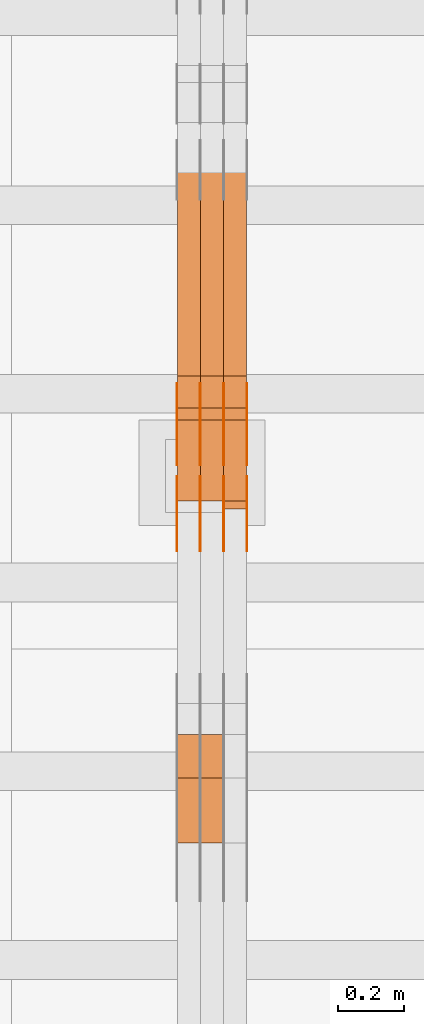
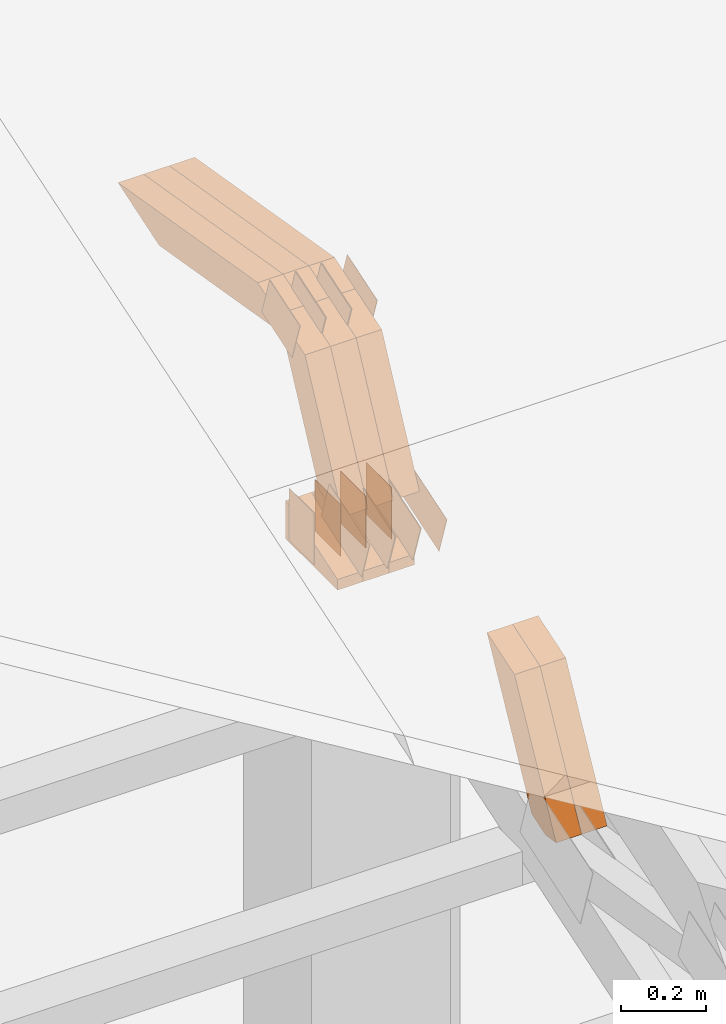
# One storey, part 145 of 385: 29 proxies.
"""IFC2X3 building model written with IfcOpenShell, lengths in millimetres."""

from ifc_helpers import new_model, entity, si_unit, converted_unit, derived_unit, direction, frame, frame_2d, origin, place, context, subcontext, project, spatial, polyline, rectangle, outline, extrude, source, transform, mapped, material, type_object, type_shapes, element, save


model = new_model("IFC2X3")

# Units and contexts
model_context = context("Model", 3, precision=0.01, world=origin(), true_north=direction((6.12303176911189e-17, 1.0)))
body_context = subcontext(model_context, "Body", "Model", "MODEL_VIEW")
ifc_project = project(units=[si_unit("LENGTHUNIT", "METRE", prefix="MILLI"), si_unit("AREAUNIT", "SQUARE_METRE"), si_unit("VOLUMEUNIT", "CUBIC_METRE"), converted_unit("PLANEANGLEUNIT", "DEGREE", entity("IfcRatioMeasure", 0.0174532925199433), si_unit("PLANEANGLEUNIT", "RADIAN"), dimensions=[0, 0, 0, 0, 0, 0, 0]), si_unit("MASSUNIT", "GRAM", prefix="KILO"), derived_unit("MASSDENSITYUNIT", [(si_unit("MASSUNIT", "GRAM", prefix="KILO"), 1), (si_unit("LENGTHUNIT", "METRE"), -3)]), si_unit("TIMEUNIT", "SECOND"), si_unit("FREQUENCYUNIT", "HERTZ"), si_unit("THERMODYNAMICTEMPERATUREUNIT", "DEGREE_CELSIUS"), derived_unit("THERMALTRANSMITTANCEUNIT", [(si_unit("MASSUNIT", "GRAM", prefix="KILO"), 1), (si_unit("THERMODYNAMICTEMPERATUREUNIT", "KELVIN"), -1), (si_unit("TIMEUNIT", "SECOND"), -3)]), derived_unit("VOLUMETRICFLOWRATEUNIT", [(si_unit("LENGTHUNIT", "METRE"), 3), (si_unit("TIMEUNIT", "SECOND"), -1)]), si_unit("ELECTRICCURRENTUNIT", "AMPERE"), si_unit("ELECTRICVOLTAGEUNIT", "VOLT"), si_unit("POWERUNIT", "WATT"), si_unit("FORCEUNIT", "NEWTON", prefix="KILO"), si_unit("ILLUMINANCEUNIT", "LUX"), si_unit("LUMINOUSFLUXUNIT", "LUMEN"), si_unit("LUMINOUSINTENSITYUNIT", "CANDELA"), derived_unit("USERDEFINED", [(si_unit("MASSUNIT", "GRAM", prefix="KILO"), -1), (si_unit("LENGTHUNIT", "METRE"), -2), (si_unit("TIMEUNIT", "SECOND"), 3), (si_unit("LUMINOUSFLUXUNIT", "LUMEN"), 1)]), derived_unit("LINEARVELOCITYUNIT", [(si_unit("LENGTHUNIT", "METRE"), 1), (si_unit("TIMEUNIT", "SECOND"), -1)]), si_unit("PRESSUREUNIT", "PASCAL"), derived_unit("USERDEFINED", [(si_unit("LENGTHUNIT", "METRE"), -2), (si_unit("MASSUNIT", "GRAM", prefix="KILO"), 1), (si_unit("TIMEUNIT", "SECOND"), -2)])], contexts=[model_context])

# Site, building, storey
site_placement = place(None, origin())
site = spatial("IfcSite", under=ifc_project, at=site_placement, CompositionType="ELEMENT")
building_placement = place(site_placement, origin())
building = spatial("IfcBuilding", under=site, at=building_placement, CompositionType="ELEMENT")
storey_placement = place(building_placement, origin())
storey = spatial("IfcBuildingStorey", under=building, at=storey_placement, Name="Default", CompositionType="ELEMENT", Elevation=0.0)

# Proxies
ifc_material_1 = material(Name="IfcSurfaceStyle #275952")
building_element_proxy_type_1 = type_object("IfcBuildingElementProxyType", PredefinedType="NOTDEFINED", material=ifc_material_1)
shared_shape_1 = source(origin(), body_context, "Body", "SweptSolid", [
    extrude(outline(polyline([(-99.9997874178038, -60.0000528641967), (99.9998102700997, -60.0000528641967), (99.9998251396068, 60.0000528641967), (-99.9998479919027, 60.0000528641967), (-99.9997874178038, -60.0000528641967)])), frame((99.9999918898597, 60.0000528641967, 0.0), z_axis=(0.0, 0.0, 1.0), x_axis=(-1.0, 0.0, 0.0)), (0.0, 0.0, 1.0), 1.3),
])
type_shapes(building_element_proxy_type_1, [shared_shape_1])
proxy_1_placement = place(building_placement, frame((21386.3, 11991.9568177725, 3072.52282247925), z_axis=(-1.0, 0.0, 0.0), x_axis=(0.0, 0.951056516295124, 0.309016994375039)))
element("IfcBuildingElementProxy", 1, at=proxy_1_placement, inside=storey, type_object=building_element_proxy_type_1, material=ifc_material_1, context=body_context, shape_type="MappedRepresentation", body=[
    mapped(shared_shape_1, transform((0.0, 0.0, 0.0), scale=1.0)),
])
ifc_material_2 = material(Name="IfcSurfaceStyle #275895")
building_element_proxy_type_2 = type_object("IfcBuildingElementProxyType", PredefinedType="NOTDEFINED", material=ifc_material_2)
shared_shape_2 = source(origin(), body_context, "Body", "SweptSolid", [
    extrude(outline(polyline([(-99.9997874178038, -60.0000528641967), (99.9998102700997, -60.0000528641967), (99.9998251396068, 60.0000528641967), (-99.9998479919027, 60.0000528641967), (-99.9997874178038, -60.0000528641967)])), frame((99.9999918898597, 60.0000528641967, 0.0), z_axis=(0.0, 0.0, 1.0), x_axis=(-1.0, 0.0, 0.0)), (0.0, 0.0, 1.0), 1.3),
])
type_shapes(building_element_proxy_type_2, [shared_shape_2])
proxy_2_placement = place(building_placement, frame((21315.0, 11991.9568177725, 3072.52282247925), z_axis=(-1.0, 0.0, 0.0), x_axis=(0.0, 0.951056516295124, 0.309016994375039)))
element("IfcBuildingElementProxy", 2, at=proxy_2_placement, inside=storey, type_object=building_element_proxy_type_2, material=ifc_material_2, context=body_context, shape_type="MappedRepresentation", body=[
    mapped(shared_shape_2, transform((0.0, 0.0, 0.0), scale=1.0)),
])
ifc_material_3 = material(Name="IfcSurfaceStyle #275838")
building_element_proxy_type_3 = type_object("IfcBuildingElementProxyType", PredefinedType="NOTDEFINED", material=ifc_material_3)
shared_shape_3 = source(origin(), body_context, "Body", "SweptSolid", [
    extrude(outline(polyline([(-99.9997874178038, -60.0000528641967), (99.9998102700997, -60.0000528641967), (99.9998251396068, 60.0000528641967), (-99.9998479919027, 60.0000528641967), (-99.9997874178038, -60.0000528641967)])), frame((99.9999918898597, 60.0000528641967, 0.0), z_axis=(0.0, 0.0, 1.0), x_axis=(-1.0, 0.0, 0.0)), (0.0, 0.0, 1.0), 1.3),
])
type_shapes(building_element_proxy_type_3, [shared_shape_3])
proxy_3_placement = place(building_placement, frame((21316.3, 11991.9568177725, 3072.52282247925), z_axis=(-1.0, 0.0, 0.0), x_axis=(0.0, 0.951056516295124, 0.309016994375039)))
element("IfcBuildingElementProxy", 3, at=proxy_3_placement, inside=storey, type_object=building_element_proxy_type_3, material=ifc_material_3, context=body_context, shape_type="MappedRepresentation", body=[
    mapped(shared_shape_3, transform((0.0, 0.0, 0.0), scale=1.0)),
])
ifc_material_4 = material(Name="IfcSurfaceStyle #275781")
building_element_proxy_type_4 = type_object("IfcBuildingElementProxyType", PredefinedType="NOTDEFINED", material=ifc_material_4)
shared_shape_4 = source(origin(), body_context, "Body", "SweptSolid", [
    extrude(outline(polyline([(-99.9997874178038, -60.0000528641967), (99.9998102700997, -60.0000528641967), (99.9998251396068, 60.0000528641967), (-99.9998479919027, 60.0000528641967), (-99.9997874178038, -60.0000528641967)])), frame((99.9999918898597, 60.0000528641967, 0.0), z_axis=(0.0, 0.0, 1.0), x_axis=(-1.0, 0.0, 0.0)), (0.0, 0.0, 1.0), 1.29999999999998),
])
type_shapes(building_element_proxy_type_4, [shared_shape_4])
proxy_4_placement = place(building_placement, frame((21245.0, 11991.9568177725, 3072.52282247925), z_axis=(-1.0, 0.0, 0.0), x_axis=(0.0, 0.951056516295124, 0.309016994375039)))
element("IfcBuildingElementProxy", 4, at=proxy_4_placement, inside=storey, type_object=building_element_proxy_type_4, material=ifc_material_4, context=body_context, shape_type="MappedRepresentation", body=[
    mapped(shared_shape_4, transform((0.0, 0.0, 0.0), scale=1.0)),
])
ifc_material_5 = material(Name="IfcSurfaceStyle #275724")
building_element_proxy_type_5 = type_object("IfcBuildingElementProxyType", PredefinedType="NOTDEFINED", material=ifc_material_5)
shared_shape_5 = source(origin(), body_context, "Body", "SweptSolid", [
    extrude(outline(polyline([(-99.9997874178038, -60.0000528641967), (99.9998102700997, -60.0000528641967), (99.9998251396068, 60.0000528641967), (-99.9998479919027, 60.0000528641967), (-99.9997874178038, -60.0000528641967)])), frame((99.9999918898597, 60.0000528641967, 0.0), z_axis=(0.0, 0.0, 1.0), x_axis=(-1.0, 0.0, 0.0)), (0.0, 0.0, 1.0), 1.29999999999998),
])
type_shapes(building_element_proxy_type_5, [shared_shape_5])
proxy_5_placement = place(building_placement, frame((21246.3, 11991.9568177725, 3072.52282247925), z_axis=(-1.0, 0.0, 0.0), x_axis=(0.0, 0.951056516295124, 0.309016994375039)))
element("IfcBuildingElementProxy", 5, at=proxy_5_placement, inside=storey, type_object=building_element_proxy_type_5, material=ifc_material_5, context=body_context, shape_type="MappedRepresentation", body=[
    mapped(shared_shape_5, transform((0.0, 0.0, 0.0), scale=1.0)),
])
ifc_material_6 = material(Name="IfcSurfaceStyle #275667")
building_element_proxy_type_6 = type_object("IfcBuildingElementProxyType", PredefinedType="NOTDEFINED", material=ifc_material_6)
shared_shape_6 = source(origin(), body_context, "Body", "SweptSolid", [
    extrude(outline(polyline([(-99.9997874178038, -60.0000528641967), (99.9998102700997, -60.0000528641967), (99.9998251396068, 60.0000528641967), (-99.9998479919027, 60.0000528641967), (-99.9997874178038, -60.0000528641967)])), frame((99.9999918898597, 60.0000528641967, 0.0), z_axis=(0.0, 0.0, 1.0), x_axis=(-1.0, 0.0, 0.0)), (0.0, 0.0, 1.0), 1.29999999999999),
])
type_shapes(building_element_proxy_type_6, [shared_shape_6])
proxy_6_placement = place(building_placement, frame((21175.0, 11991.9568177725, 3072.52282247925), z_axis=(-1.0, 0.0, 0.0), x_axis=(0.0, 0.951056516295124, 0.309016994375039)))
element("IfcBuildingElementProxy", 6, at=proxy_6_placement, inside=storey, type_object=building_element_proxy_type_6, material=ifc_material_6, context=body_context, shape_type="MappedRepresentation", body=[
    mapped(shared_shape_6, transform((0.0, 0.0, 0.0), scale=1.0)),
])
ifc_material_7 = material(Name="IfcSurfaceStyle #275610")
building_element_proxy_type_7 = type_object("IfcBuildingElementProxyType", PredefinedType="NOTDEFINED", material=ifc_material_7)
shared_shape_7 = source(origin(), body_context, "Body", "SweptSolid", [
    extrude(rectangle(XDim=150.0, YDim=119.999999999985, at=frame_2d((-7.105427357601e-15, 0.0), x_axis=(1.0, 0.0))), frame((75.0, 60.0, 0.0), z_axis=(0.0, 0.0, 1.0), x_axis=(-1.0, 0.0, 0.0)), (0.0, 0.0, 1.0), 1.3),
])
type_shapes(building_element_proxy_type_7, [shared_shape_7])
proxy_7_placement = place(building_placement, frame((21386.3, 12372.95703125, 3007.04687500001), z_axis=(-1.0, 0.0, 0.0), x_axis=(0.0, 0.0, -1.0)))
element("IfcBuildingElementProxy", 7, at=proxy_7_placement, inside=storey, type_object=building_element_proxy_type_7, material=ifc_material_7, context=body_context, shape_type="MappedRepresentation", body=[
    mapped(shared_shape_7, transform((0.0, 0.0, 0.0), scale=1.0)),
])
ifc_material_8 = material(Name="IfcSurfaceStyle #275553")
building_element_proxy_type_8 = type_object("IfcBuildingElementProxyType", PredefinedType="NOTDEFINED", material=ifc_material_8)
shared_shape_8 = source(origin(), body_context, "Body", "SweptSolid", [
    extrude(rectangle(XDim=150.0, YDim=119.999999999985, at=frame_2d((-7.105427357601e-15, 0.0), x_axis=(1.0, 0.0))), frame((75.0, 60.0, 0.0), z_axis=(0.0, 0.0, 1.0), x_axis=(-1.0, 0.0, 0.0)), (0.0, 0.0, 1.0), 1.3),
])
type_shapes(building_element_proxy_type_8, [shared_shape_8])
proxy_8_placement = place(building_placement, frame((21315.0, 12372.95703125, 3007.04687500001), z_axis=(-1.0, 0.0, 0.0), x_axis=(0.0, 0.0, -1.0)))
element("IfcBuildingElementProxy", 8, at=proxy_8_placement, inside=storey, type_object=building_element_proxy_type_8, material=ifc_material_8, context=body_context, shape_type="MappedRepresentation", body=[
    mapped(shared_shape_8, transform((0.0, 0.0, 0.0), scale=1.0)),
])
ifc_material_9 = material(Name="IfcSurfaceStyle #275496")
building_element_proxy_type_9 = type_object("IfcBuildingElementProxyType", PredefinedType="NOTDEFINED", material=ifc_material_9)
shared_shape_9 = source(origin(), body_context, "Body", "SweptSolid", [
    extrude(rectangle(XDim=150.0, YDim=119.999999999985, at=frame_2d((-7.105427357601e-15, 0.0), x_axis=(1.0, 0.0))), frame((75.0, 60.0, 0.0), z_axis=(0.0, 0.0, 1.0), x_axis=(-1.0, 0.0, 0.0)), (0.0, 0.0, 1.0), 1.3),
])
type_shapes(building_element_proxy_type_9, [shared_shape_9])
proxy_9_placement = place(building_placement, frame((21316.3, 12372.95703125, 3007.04687500001), z_axis=(-1.0, 0.0, 0.0), x_axis=(0.0, 0.0, -1.0)))
element("IfcBuildingElementProxy", 9, at=proxy_9_placement, inside=storey, type_object=building_element_proxy_type_9, material=ifc_material_9, context=body_context, shape_type="MappedRepresentation", body=[
    mapped(shared_shape_9, transform((0.0, 0.0, 0.0), scale=1.0)),
])
ifc_material_10 = material(Name="IfcSurfaceStyle #275439")
building_element_proxy_type_10 = type_object("IfcBuildingElementProxyType", PredefinedType="NOTDEFINED", material=ifc_material_10)
shared_shape_10 = source(origin(), body_context, "Body", "SweptSolid", [
    extrude(rectangle(XDim=150.0, YDim=119.999999999985, at=frame_2d((-7.105427357601e-15, 0.0), x_axis=(1.0, 0.0))), frame((75.0, 60.0, 0.0), z_axis=(0.0, 0.0, 1.0), x_axis=(-1.0, 0.0, 0.0)), (0.0, 0.0, 1.0), 1.29999999999999),
])
type_shapes(building_element_proxy_type_10, [shared_shape_10])
proxy_10_placement = place(building_placement, frame((21245.0, 12372.95703125, 3007.04687500001), z_axis=(-1.0, 0.0, 0.0), x_axis=(0.0, 0.0, -1.0)))
element("IfcBuildingElementProxy", 10, at=proxy_10_placement, inside=storey, type_object=building_element_proxy_type_10, material=ifc_material_10, context=body_context, shape_type="MappedRepresentation", body=[
    mapped(shared_shape_10, transform((0.0, 0.0, 0.0), scale=1.0)),
])
ifc_material_11 = material(Name="IfcSurfaceStyle #275382")
building_element_proxy_type_11 = type_object("IfcBuildingElementProxyType", PredefinedType="NOTDEFINED", material=ifc_material_11)
shared_shape_11 = source(origin(), body_context, "Body", "SweptSolid", [
    extrude(rectangle(XDim=150.0, YDim=119.999999999985, at=frame_2d((-7.105427357601e-15, 0.0), x_axis=(1.0, 0.0))), frame((75.0, 60.0, 0.0), z_axis=(0.0, 0.0, 1.0), x_axis=(-1.0, 0.0, 0.0)), (0.0, 0.0, 1.0), 1.29999999999999),
])
type_shapes(building_element_proxy_type_11, [shared_shape_11])
proxy_11_placement = place(building_placement, frame((21246.3, 12372.95703125, 3007.04687500001), z_axis=(-1.0, 0.0, 0.0), x_axis=(0.0, 0.0, -1.0)))
element("IfcBuildingElementProxy", 11, at=proxy_11_placement, inside=storey, type_object=building_element_proxy_type_11, material=ifc_material_11, context=body_context, shape_type="MappedRepresentation", body=[
    mapped(shared_shape_11, transform((0.0, 0.0, 0.0), scale=1.0)),
])
ifc_material_12 = material(Name="IfcSurfaceStyle #275325")
building_element_proxy_type_12 = type_object("IfcBuildingElementProxyType", PredefinedType="NOTDEFINED", material=ifc_material_12)
shared_shape_12 = source(origin(), body_context, "Body", "SweptSolid", [
    extrude(rectangle(XDim=150.0, YDim=119.999999999985, at=frame_2d((-7.105427357601e-15, 0.0), x_axis=(1.0, 0.0))), frame((75.0, 60.0, 0.0), z_axis=(0.0, 0.0, 1.0), x_axis=(-1.0, 0.0, 0.0)), (0.0, 0.0, 1.0), 1.29999999999999),
])
type_shapes(building_element_proxy_type_12, [shared_shape_12])
proxy_12_placement = place(building_placement, frame((21175.0, 12372.95703125, 3007.04687500001), z_axis=(-1.0, 0.0, 0.0), x_axis=(0.0, 0.0, -1.0)))
element("IfcBuildingElementProxy", 12, at=proxy_12_placement, inside=storey, type_object=building_element_proxy_type_12, material=ifc_material_12, context=body_context, shape_type="MappedRepresentation", body=[
    mapped(shared_shape_12, transform((0.0, 0.0, 0.0), scale=1.0)),
])
ifc_material_13 = material(Name="IfcSurfaceStyle #268428")
building_element_proxy_type_13 = type_object("IfcBuildingElementProxyType", PredefinedType="NOTDEFINED", material=ifc_material_13)
shared_shape_13 = source(origin(), body_context, "Body", "SweptSolid", [
    extrude(outline(polyline([(-74.9998754286244, -60.0000016373506), (74.9998605591063, -60.0000016373506), (74.9998754286244, 60.0000016373506), (-74.9998605591063, 60.0000016373506), (-74.9998754286244, -60.0000016373506)])), frame((74.9998754286244, 60.0000016373506, 0.0), z_axis=(0.0, 0.0, 1.0), x_axis=(-1.0, 0.0, 0.0)), (0.0, 0.0, 1.0), 1.3),
])
type_shapes(building_element_proxy_type_13, [shared_shape_13])
proxy_13_placement = place(building_placement, frame((21386.3, 12321.1620861463, 3506.17707344366), z_axis=(-1.0, 0.0, 0.0), x_axis=(0.0, 0.951056516295154, 0.309016994374948)))
element("IfcBuildingElementProxy", 13, at=proxy_13_placement, inside=storey, type_object=building_element_proxy_type_13, material=ifc_material_13, context=body_context, shape_type="MappedRepresentation", body=[
    mapped(shared_shape_13, transform((0.0, 0.0, 0.0), scale=1.0)),
])
ifc_material_14 = material(Name="IfcSurfaceStyle #268371")
building_element_proxy_type_14 = type_object("IfcBuildingElementProxyType", PredefinedType="NOTDEFINED", material=ifc_material_14)
shared_shape_14 = source(origin(), body_context, "Body", "SweptSolid", [
    extrude(outline(polyline([(-74.9998754286244, -60.0000016373506), (74.9998605591063, -60.0000016373506), (74.9998754286244, 60.0000016373506), (-74.9998605591063, 60.0000016373506), (-74.9998754286244, -60.0000016373506)])), frame((74.9998754286244, 60.0000016373506, 0.0), z_axis=(0.0, 0.0, 1.0), x_axis=(-1.0, 0.0, 0.0)), (0.0, 0.0, 1.0), 1.3),
])
type_shapes(building_element_proxy_type_14, [shared_shape_14])
proxy_14_placement = place(building_placement, frame((21315.0, 12321.1620861463, 3506.17707344366), z_axis=(-1.0, 0.0, 0.0), x_axis=(0.0, 0.951056516295154, 0.309016994374948)))
element("IfcBuildingElementProxy", 14, at=proxy_14_placement, inside=storey, type_object=building_element_proxy_type_14, material=ifc_material_14, context=body_context, shape_type="MappedRepresentation", body=[
    mapped(shared_shape_14, transform((0.0, 0.0, 0.0), scale=1.0)),
])
ifc_material_15 = material(Name="IfcSurfaceStyle #268314")
building_element_proxy_type_15 = type_object("IfcBuildingElementProxyType", PredefinedType="NOTDEFINED", material=ifc_material_15)
shared_shape_15 = source(origin(), body_context, "Body", "SweptSolid", [
    extrude(outline(polyline([(-74.9998754286244, -60.0000016373506), (74.9998605591063, -60.0000016373506), (74.9998754286244, 60.0000016373506), (-74.9998605591063, 60.0000016373506), (-74.9998754286244, -60.0000016373506)])), frame((74.9998754286244, 60.0000016373506, 0.0), z_axis=(0.0, 0.0, 1.0), x_axis=(-1.0, 0.0, 0.0)), (0.0, 0.0, 1.0), 1.3),
])
type_shapes(building_element_proxy_type_15, [shared_shape_15])
proxy_15_placement = place(building_placement, frame((21316.3, 12321.1620861463, 3506.17707344366), z_axis=(-1.0, 0.0, 0.0), x_axis=(0.0, 0.951056516295154, 0.309016994374948)))
element("IfcBuildingElementProxy", 15, at=proxy_15_placement, inside=storey, type_object=building_element_proxy_type_15, material=ifc_material_15, context=body_context, shape_type="MappedRepresentation", body=[
    mapped(shared_shape_15, transform((0.0, 0.0, 0.0), scale=1.0)),
])
ifc_material_16 = material(Name="IfcSurfaceStyle #268257")
building_element_proxy_type_16 = type_object("IfcBuildingElementProxyType", PredefinedType="NOTDEFINED", material=ifc_material_16)
shared_shape_16 = source(origin(), body_context, "Body", "SweptSolid", [
    extrude(outline(polyline([(-74.9998754286244, -60.0000016373506), (74.9998605591063, -60.0000016373506), (74.9998754286244, 60.0000016373506), (-74.9998605591063, 60.0000016373506), (-74.9998754286244, -60.0000016373506)])), frame((74.9998754286244, 60.0000016373506, 0.0), z_axis=(0.0, 0.0, 1.0), x_axis=(-1.0, 0.0, 0.0)), (0.0, 0.0, 1.0), 1.29999999999999),
])
type_shapes(building_element_proxy_type_16, [shared_shape_16])
proxy_16_placement = place(building_placement, frame((21245.0, 12321.1620861463, 3506.17707344366), z_axis=(-1.0, 0.0, 0.0), x_axis=(0.0, 0.951056516295154, 0.309016994374948)))
element("IfcBuildingElementProxy", 16, at=proxy_16_placement, inside=storey, type_object=building_element_proxy_type_16, material=ifc_material_16, context=body_context, shape_type="MappedRepresentation", body=[
    mapped(shared_shape_16, transform((0.0, 0.0, 0.0), scale=1.0)),
])
ifc_material_17 = material(Name="IfcSurfaceStyle #268200")
building_element_proxy_type_17 = type_object("IfcBuildingElementProxyType", PredefinedType="NOTDEFINED", material=ifc_material_17)
shared_shape_17 = source(origin(), body_context, "Body", "SweptSolid", [
    extrude(outline(polyline([(-74.9998754286244, -60.0000016373506), (74.9998605591063, -60.0000016373506), (74.9998754286244, 60.0000016373506), (-74.9998605591063, 60.0000016373506), (-74.9998754286244, -60.0000016373506)])), frame((74.9998754286244, 60.0000016373506, 0.0), z_axis=(0.0, 0.0, 1.0), x_axis=(-1.0, 0.0, 0.0)), (0.0, 0.0, 1.0), 1.29999999999999),
])
type_shapes(building_element_proxy_type_17, [shared_shape_17])
proxy_17_placement = place(building_placement, frame((21246.3, 12321.1620861463, 3506.17707344366), z_axis=(-1.0, 0.0, 0.0), x_axis=(0.0, 0.951056516295154, 0.309016994374948)))
element("IfcBuildingElementProxy", 17, at=proxy_17_placement, inside=storey, type_object=building_element_proxy_type_17, material=ifc_material_17, context=body_context, shape_type="MappedRepresentation", body=[
    mapped(shared_shape_17, transform((0.0, 0.0, 0.0), scale=1.0)),
])
ifc_material_18 = material(Name="IfcSurfaceStyle #268143")
building_element_proxy_type_18 = type_object("IfcBuildingElementProxyType", PredefinedType="NOTDEFINED", material=ifc_material_18)
shared_shape_18 = source(origin(), body_context, "Body", "SweptSolid", [
    extrude(outline(polyline([(-74.9998754286244, -60.0000016373506), (74.9998605591063, -60.0000016373506), (74.9998754286244, 60.0000016373506), (-74.9998605591063, 60.0000016373506), (-74.9998754286244, -60.0000016373506)])), frame((74.9998754286244, 60.0000016373506, 0.0), z_axis=(0.0, 0.0, 1.0), x_axis=(-1.0, 0.0, 0.0)), (0.0, 0.0, 1.0), 1.29999999999999),
])
type_shapes(building_element_proxy_type_18, [shared_shape_18])
proxy_18_placement = place(building_placement, frame((21175.0, 12321.1620861463, 3506.17707344366), z_axis=(-1.0, 0.0, 0.0), x_axis=(0.0, 0.951056516295154, 0.309016994374948)))
element("IfcBuildingElementProxy", 18, at=proxy_18_placement, inside=storey, type_object=building_element_proxy_type_18, material=ifc_material_18, context=body_context, shape_type="MappedRepresentation", body=[
    mapped(shared_shape_18, transform((0.0, 0.0, 0.0), scale=1.0)),
])
ifc_material_19 = material(Name="IfcSurfaceStyle #259968")
building_element_proxy_type_19 = type_object("IfcBuildingElementProxyType", Name="T1-E1 259966", PredefinedType="NOTDEFINED", material=ifc_material_19)
shared_shape_19 = source(origin(), body_context, "Body", "SweptSolid", [
    extrude(outline(polyline([(-75.1378173828004, -122.500000000005), (35.3350830078246, -122.500000000005), (35.3350830078004, 122.500000000005), (4.46765136717545, 122.500000000005), (-75.1378173828004, -122.500000000005)])), frame((35.3350830078246, 122.500000104877, 0.0), z_axis=(0.0, 0.0, 1.0), x_axis=(-1.0, 0.0, 0.0)), (0.0, 0.0, 1.0), 70.0),
])
type_shapes(building_element_proxy_type_19, [shared_shape_19])
proxy_19_placement = place(building_placement, frame((21385.0, 12145.0, 2849.54565429685), z_axis=(-1.0, 0.0, 0.0), x_axis=(0.0, 0.0, 1.0)))
element("IfcBuildingElementProxy", 19, at=proxy_19_placement, inside=storey, type_object=building_element_proxy_type_19, material=ifc_material_19, Name="T1-E1", context=body_context, shape_type="MappedRepresentation", body=[
    mapped(shared_shape_19, transform((0.0, 0.0, 0.0), scale=1.0)),
])
ifc_material_20 = material(Name="IfcSurfaceStyle #259911")
building_element_proxy_type_20 = type_object("IfcBuildingElementProxyType", Name="T1-E1 259909", PredefinedType="NOTDEFINED", material=ifc_material_20)
shared_shape_20 = source(origin(), body_context, "Body", "SweptSolid", [
    extrude(outline(polyline([(-75.1378173828004, -122.500000000005), (35.3350830078246, -122.500000000005), (35.3350830078004, 122.500000000005), (4.46765136717545, 122.500000000005), (-75.1378173828004, -122.500000000005)])), frame((35.3350830078246, 122.500000104877, 0.0), z_axis=(0.0, 0.0, 1.0), x_axis=(-1.0, 0.0, 0.0)), (0.0, 0.0, 1.0), 70.0),
])
type_shapes(building_element_proxy_type_20, [shared_shape_20])
proxy_20_placement = place(building_placement, frame((21315.0, 12145.0, 2849.54565429685), z_axis=(-1.0, 0.0, 0.0), x_axis=(0.0, 0.0, 1.0)))
element("IfcBuildingElementProxy", 20, at=proxy_20_placement, inside=storey, type_object=building_element_proxy_type_20, material=ifc_material_20, Name="T1-E1", context=body_context, shape_type="MappedRepresentation", body=[
    mapped(shared_shape_20, transform((0.0, 0.0, 0.0), scale=1.0)),
])
ifc_material_21 = material(Name="IfcSurfaceStyle #259854")
building_element_proxy_type_21 = type_object("IfcBuildingElementProxyType", Name="T1-E1 259852", PredefinedType="NOTDEFINED", material=ifc_material_21)
shared_shape_21 = source(origin(), body_context, "Body", "SweptSolid", [
    extrude(outline(polyline([(-75.1378173828004, -122.500000000005), (35.3350830078246, -122.500000000005), (35.3350830078004, 122.500000000005), (4.46765136717545, 122.500000000005), (-75.1378173828004, -122.500000000005)])), frame((35.3350830078246, 122.500000104877, 0.0), z_axis=(0.0, 0.0, 1.0), x_axis=(-1.0, 0.0, 0.0)), (0.0, 0.0, 1.0), 70.0),
])
type_shapes(building_element_proxy_type_21, [shared_shape_21])
proxy_21_placement = place(building_placement, frame((21245.0, 12145.0, 2849.54565429685), z_axis=(-1.0, 0.0, 0.0), x_axis=(0.0, 0.0, 1.0)))
element("IfcBuildingElementProxy", 21, at=proxy_21_placement, inside=storey, type_object=building_element_proxy_type_21, material=ifc_material_21, Name="T1-E1", context=body_context, shape_type="MappedRepresentation", body=[
    mapped(shared_shape_21, transform((0.0, 0.0, 0.0), scale=1.0)),
])
ifc_material_22 = material(Name="IfcSurfaceStyle #258240")
building_element_proxy_type_22 = type_object("IfcBuildingElementProxyType", Name="T1-W7 258238", PredefinedType="NOTDEFINED", material=ifc_material_22)
shared_shape_22 = source(origin(), body_context, "Body", "SweptSolid", [
    extrude(outline(polyline([(-296.174043820986, -47.5000676566704), (297.841254477443, -47.5000676566704), (283.518570346415, -7.10254316533821e-06), (192.674144473719, 47.500071207942), (-477.859925476591, 47.500071207942), (-296.174043820986, -47.5000676566704)])), frame((297.841254477443, 47.5000816097442, 0.0), z_axis=(0.0, 0.0, 1.0), x_axis=(-1.0, 0.0, 0.0)), (0.0, 0.0, 1.0), 70.0),
])
type_shapes(building_element_proxy_type_22, [shared_shape_22])
proxy_22_placement = place(building_placement, frame((21385.0, 12419.2991208897, 3526.2136755972), z_axis=(-1.0, 0.0, 0.0), x_axis=(0.0, 0.985983815111804, -0.166840991178939)))
element("IfcBuildingElementProxy", 22, at=proxy_22_placement, inside=storey, type_object=building_element_proxy_type_22, material=ifc_material_22, Name="T1-W7", context=body_context, shape_type="MappedRepresentation", body=[
    mapped(shared_shape_22, transform((0.0, 0.0, 0.0), scale=1.0)),
])
ifc_material_23 = material(Name="IfcSurfaceStyle #258174")
building_element_proxy_type_23 = type_object("IfcBuildingElementProxyType", Name="T1-W7 258172", PredefinedType="NOTDEFINED", material=ifc_material_23)
shared_shape_23 = source(origin(), body_context, "Body", "SweptSolid", [
    extrude(outline(polyline([(-296.174043820986, -47.5000676566704), (297.841254477443, -47.5000676566704), (283.518570346415, -7.10254316533821e-06), (192.674144473719, 47.500071207942), (-477.859925476591, 47.500071207942), (-296.174043820986, -47.5000676566704)])), frame((297.841254477443, 47.5000816097442, 0.0), z_axis=(0.0, 0.0, 1.0), x_axis=(-1.0, 0.0, 0.0)), (0.0, 0.0, 1.0), 70.0),
])
type_shapes(building_element_proxy_type_23, [shared_shape_23])
proxy_23_placement = place(building_placement, frame((21315.0, 12419.2991208897, 3526.2136755972), z_axis=(-1.0, 0.0, 0.0), x_axis=(0.0, 0.985983815111804, -0.166840991178939)))
element("IfcBuildingElementProxy", 23, at=proxy_23_placement, inside=storey, type_object=building_element_proxy_type_23, material=ifc_material_23, Name="T1-W7", context=body_context, shape_type="MappedRepresentation", body=[
    mapped(shared_shape_23, transform((0.0, 0.0, 0.0), scale=1.0)),
])
ifc_material_24 = material(Name="IfcSurfaceStyle #258108")
building_element_proxy_type_24 = type_object("IfcBuildingElementProxyType", Name="T1-W7 258106", PredefinedType="NOTDEFINED", material=ifc_material_24)
shared_shape_24 = source(origin(), body_context, "Body", "SweptSolid", [
    extrude(outline(polyline([(-296.174043820986, -47.5000676566704), (297.841254477443, -47.5000676566704), (283.518570346415, -7.10254316533821e-06), (192.674144473719, 47.500071207942), (-477.859925476591, 47.500071207942), (-296.174043820986, -47.5000676566704)])), frame((297.841254477443, 47.5000816097442, 0.0), z_axis=(0.0, 0.0, 1.0), x_axis=(-1.0, 0.0, 0.0)), (0.0, 0.0, 1.0), 70.0),
])
type_shapes(building_element_proxy_type_24, [shared_shape_24])
proxy_24_placement = place(building_placement, frame((21245.0, 12419.2991208897, 3526.2136755972), z_axis=(-1.0, 0.0, 0.0), x_axis=(0.0, 0.985983815111804, -0.166840991178939)))
element("IfcBuildingElementProxy", 24, at=proxy_24_placement, inside=storey, type_object=building_element_proxy_type_24, material=ifc_material_24, Name="T1-W7", context=body_context, shape_type="MappedRepresentation", body=[
    mapped(shared_shape_24, transform((0.0, 0.0, 0.0), scale=1.0)),
])
ifc_material_25 = material(Name="IfcSurfaceStyle #257844")
building_element_proxy_type_25 = type_object("IfcBuildingElementProxyType", Name="T1-W36 257842", PredefinedType="NOTDEFINED", material=ifc_material_25)
shared_shape_25 = source(origin(), body_context, "Body", "SweptSolid", [
    extrude(outline(polyline([(-300.714670922549, -47.4998881108849), (134.031527004269, -47.499888110885), (180.52054953879, -0.000136170977331764), (193.89900152221, 47.500563476126), (-207.736407142719, 47.4993489166213), (-300.714670922549, -47.4998881108849)])), frame((193.899145164686, 47.5001861375837, 0.0), z_axis=(0.0, 0.0, 1.0), x_axis=(-1.0, 3.02403492980632e-06, 0.0)), (0.0, 0.0, 1.0), 70.0),
])
type_shapes(building_element_proxy_type_25, [shared_shape_25])
proxy_25_placement = place(building_placement, frame((21385.0, 12120.5935627532, 3076.1128858536), z_axis=(-1.0, 0.0, 0.0), x_axis=(0.0, 0.444384650266842, 0.895836080210669)))
element("IfcBuildingElementProxy", 25, at=proxy_25_placement, inside=storey, type_object=building_element_proxy_type_25, material=ifc_material_25, Name="T1-W36", context=body_context, shape_type="MappedRepresentation", body=[
    mapped(shared_shape_25, transform((0.0, 0.0, 0.0), scale=1.0)),
])
ifc_material_26 = material(Name="IfcSurfaceStyle #257778")
building_element_proxy_type_26 = type_object("IfcBuildingElementProxyType", Name="T1-W36 257776", PredefinedType="NOTDEFINED", material=ifc_material_26)
shared_shape_26 = source(origin(), body_context, "Body", "SweptSolid", [
    extrude(outline(polyline([(-300.714670922549, -47.4998881108849), (134.031527004269, -47.499888110885), (180.52054953879, -0.000136170977331764), (193.89900152221, 47.500563476126), (-207.736407142719, 47.4993489166213), (-300.714670922549, -47.4998881108849)])), frame((193.899145164686, 47.5001861375837, 0.0), z_axis=(0.0, 0.0, 1.0), x_axis=(-1.0, 3.02403492980632e-06, 0.0)), (0.0, 0.0, 1.0), 70.0),
])
type_shapes(building_element_proxy_type_26, [shared_shape_26])
proxy_26_placement = place(building_placement, frame((21315.0, 12120.5935627532, 3076.1128858536), z_axis=(-1.0, 0.0, 0.0), x_axis=(0.0, 0.444384650266842, 0.895836080210669)))
element("IfcBuildingElementProxy", 26, at=proxy_26_placement, inside=storey, type_object=building_element_proxy_type_26, material=ifc_material_26, Name="T1-W36", context=body_context, shape_type="MappedRepresentation", body=[
    mapped(shared_shape_26, transform((0.0, 0.0, 0.0), scale=1.0)),
])
ifc_material_27 = material(Name="IfcSurfaceStyle #257712")
building_element_proxy_type_27 = type_object("IfcBuildingElementProxyType", Name="T1-W36 257710", PredefinedType="NOTDEFINED", material=ifc_material_27)
shared_shape_27 = source(origin(), body_context, "Body", "SweptSolid", [
    extrude(outline(polyline([(-300.714670922549, -47.4998881108849), (134.031527004269, -47.499888110885), (180.52054953879, -0.000136170977331764), (193.89900152221, 47.500563476126), (-207.736407142719, 47.4993489166213), (-300.714670922549, -47.4998881108849)])), frame((193.899145164686, 47.5001861375837, 0.0), z_axis=(0.0, 0.0, 1.0), x_axis=(-1.0, 3.02403492980632e-06, 0.0)), (0.0, 0.0, 1.0), 70.0),
])
type_shapes(building_element_proxy_type_27, [shared_shape_27])
proxy_27_placement = place(building_placement, frame((21245.0, 12120.5935627532, 3076.1128858536), z_axis=(-1.0, 0.0, 0.0), x_axis=(0.0, 0.444384650266842, 0.895836080210669)))
element("IfcBuildingElementProxy", 27, at=proxy_27_placement, inside=storey, type_object=building_element_proxy_type_27, material=ifc_material_27, Name="T1-W36", context=body_context, shape_type="MappedRepresentation", body=[
    mapped(shared_shape_27, transform((0.0, 0.0, 0.0), scale=1.0)),
])
ifc_material_28 = material(Name="IfcSurfaceStyle #256986")
building_element_proxy_type_28 = type_object("IfcBuildingElementProxyType", Name="T1-W32 256984", PredefinedType="NOTDEFINED", material=ifc_material_28)
shared_shape_28 = source(origin(), body_context, "Body", "SweptSolid", [
    extrude(outline(polyline([(-312.414547135921, -47.5000544873059), (136.677011757652, -47.5000544873059), (186.250996577889, 0.000369497452627243), (202.753116295831, 47.4998697385796), (-213.26657749545, 47.4998697385796), (-312.414547135921, -47.5000544873059)])), frame((202.753376481939, 47.5001296985553, 0.0), z_axis=(0.0, 0.0, 1.0), x_axis=(-1.0, 0.0, 0.0)), (0.0, 0.0, 1.0), 70.0),
])
type_shapes(building_element_proxy_type_28, [shared_shape_28])
proxy_28_placement = place(building_placement, frame((21315.0, 11110.7808979007, 2747.18129017315), z_axis=(-1.0, 0.0, 0.0), x_axis=(0.0, 0.472919689385906, 0.881105537033526)))
element("IfcBuildingElementProxy", 28, at=proxy_28_placement, inside=storey, type_object=building_element_proxy_type_28, material=ifc_material_28, Name="T1-W32", context=body_context, shape_type="MappedRepresentation", body=[
    mapped(shared_shape_28, transform((0.0, 0.0, 0.0), scale=1.0)),
])
ifc_material_29 = material(Name="IfcSurfaceStyle #256920")
building_element_proxy_type_29 = type_object("IfcBuildingElementProxyType", Name="T1-W32 256918", PredefinedType="NOTDEFINED", material=ifc_material_29)
shared_shape_29 = source(origin(), body_context, "Body", "SweptSolid", [
    extrude(outline(polyline([(-312.414547135921, -47.5000544873059), (136.677011757652, -47.5000544873059), (186.250996577889, 0.000369497452627243), (202.753116295831, 47.4998697385796), (-213.26657749545, 47.4998697385796), (-312.414547135921, -47.5000544873059)])), frame((202.753376481939, 47.5001296985553, 0.0), z_axis=(0.0, 0.0, 1.0), x_axis=(-1.0, 0.0, 0.0)), (0.0, 0.0, 1.0), 70.0),
])
type_shapes(building_element_proxy_type_29, [shared_shape_29])
proxy_29_placement = place(building_placement, frame((21245.0, 11110.7808979007, 2747.18129017315), z_axis=(-1.0, 0.0, 0.0), x_axis=(0.0, 0.472919689385906, 0.881105537033526)))
element("IfcBuildingElementProxy", 29, at=proxy_29_placement, inside=storey, type_object=building_element_proxy_type_29, material=ifc_material_29, Name="T1-W32", context=body_context, shape_type="MappedRepresentation", body=[
    mapped(shared_shape_29, transform((0.0, 0.0, 0.0), scale=1.0)),
])

save(model, "model.ifc")
